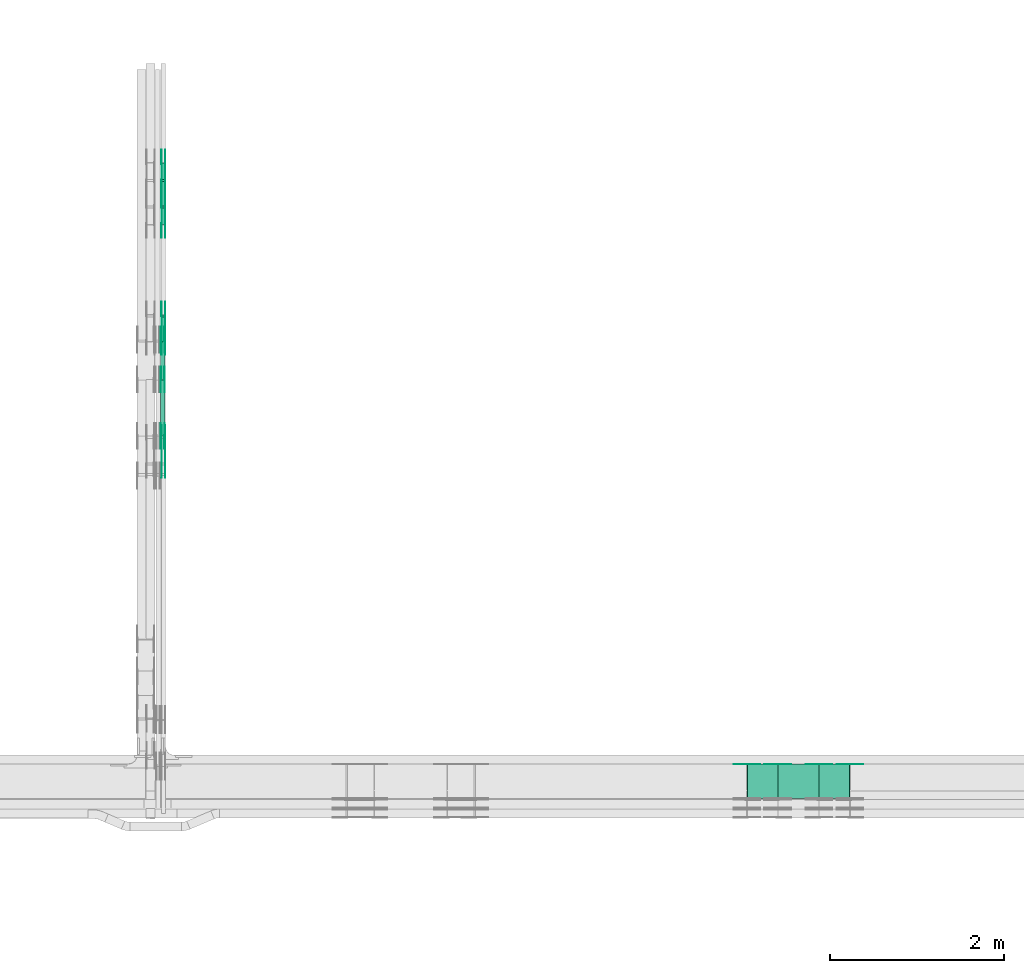
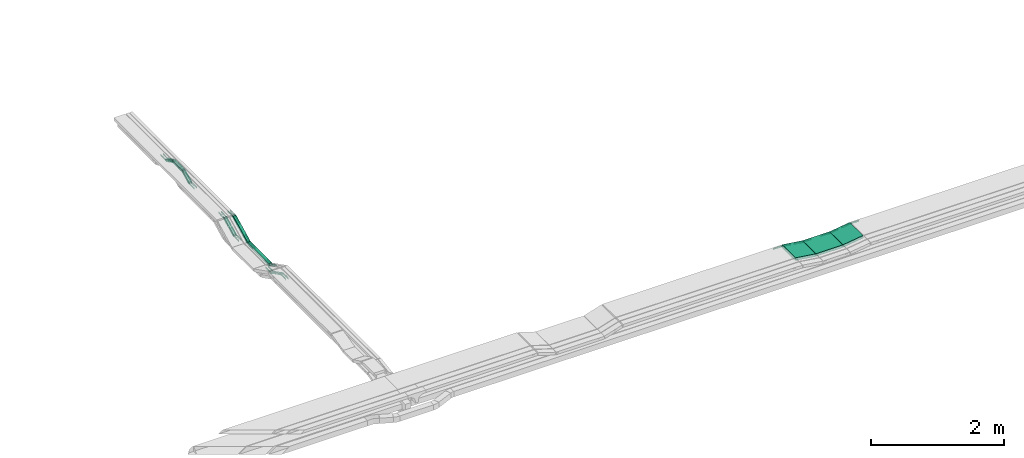
# One storey, part 20 of 27: 52 flow fittings, 9 flow segments.
"""IFC2X3 building model written with IfcOpenShell, lengths in millimetres."""

from ifc_helpers import new_model, entity, si_unit, converted_unit, derived_unit, direction, frame, frame_2d, origin, origin_2d_with_axis, place, context, subcontext, project, spatial, polyline, circle_curve, parameter, trimmed, segment, composite_curve, rectangle, outline, extrude, source, transform, mapped, material, type_object, type_shapes, element, save


model = new_model("IFC2X3")

# Units and contexts
model_context = context("Model", 3, precision=0.01, world=origin(), true_north=direction((6.12303176911189e-17, 1.0)))
body_context = subcontext(model_context, "Body", "Model", "MODEL_VIEW")
ifc_project = project(units=[si_unit("LENGTHUNIT", "METRE", prefix="MILLI"), si_unit("AREAUNIT", "SQUARE_METRE"), si_unit("VOLUMEUNIT", "CUBIC_METRE"), converted_unit("PLANEANGLEUNIT", "DEGREE", entity("IfcRatioMeasure", 0.0174532925199433), si_unit("PLANEANGLEUNIT", "RADIAN"), dimensions=[0, 0, 0, 0, 0, 0, 0]), si_unit("MASSUNIT", "GRAM", prefix="KILO"), derived_unit("MASSDENSITYUNIT", [(si_unit("MASSUNIT", "GRAM", prefix="KILO"), 1), (si_unit("LENGTHUNIT", "METRE"), -3)]), derived_unit("MOMENTOFINERTIAUNIT", [(si_unit("LENGTHUNIT", "METRE"), 4)]), si_unit("TIMEUNIT", "SECOND"), si_unit("FREQUENCYUNIT", "HERTZ"), si_unit("THERMODYNAMICTEMPERATUREUNIT", "DEGREE_CELSIUS"), derived_unit("THERMALTRANSMITTANCEUNIT", [(si_unit("MASSUNIT", "GRAM", prefix="KILO"), 1), (si_unit("THERMODYNAMICTEMPERATUREUNIT", "KELVIN"), -1), (si_unit("TIMEUNIT", "SECOND"), -3)]), derived_unit("VOLUMETRICFLOWRATEUNIT", [(si_unit("LENGTHUNIT", "METRE"), 3), (si_unit("TIMEUNIT", "SECOND"), -1)]), derived_unit("MASSFLOWRATEUNIT", [(si_unit("MASSUNIT", "GRAM", prefix="KILO"), 1), (si_unit("TIMEUNIT", "SECOND"), -1)]), derived_unit("ROTATIONALFREQUENCYUNIT", [(si_unit("TIMEUNIT", "SECOND"), -1)]), si_unit("ELECTRICCURRENTUNIT", "AMPERE"), si_unit("ELECTRICVOLTAGEUNIT", "VOLT"), si_unit("POWERUNIT", "WATT"), si_unit("FORCEUNIT", "NEWTON", prefix="KILO"), si_unit("ILLUMINANCEUNIT", "LUX"), si_unit("LUMINOUSFLUXUNIT", "LUMEN"), si_unit("LUMINOUSINTENSITYUNIT", "CANDELA"), derived_unit("USERDEFINED", [(si_unit("MASSUNIT", "GRAM", prefix="KILO"), -1), (si_unit("LENGTHUNIT", "METRE"), -2), (si_unit("TIMEUNIT", "SECOND"), 3), (si_unit("LUMINOUSFLUXUNIT", "LUMEN"), 1)]), derived_unit("LINEARVELOCITYUNIT", [(si_unit("LENGTHUNIT", "METRE"), 1), (si_unit("TIMEUNIT", "SECOND"), -1)]), si_unit("PRESSUREUNIT", "PASCAL"), derived_unit("USERDEFINED", [(si_unit("LENGTHUNIT", "METRE"), -2), (si_unit("MASSUNIT", "GRAM", prefix="KILO"), 1), (si_unit("TIMEUNIT", "SECOND"), -2)]), derived_unit("LINEARFORCEUNIT", [(si_unit("MASSUNIT", "GRAM", prefix="KILO"), 1), (si_unit("LENGTHUNIT", "METRE"), 1), (si_unit("TIMEUNIT", "SECOND"), -2), (si_unit("LENGTHUNIT", "METRE"), -1)]), derived_unit("PLANARFORCEUNIT", [(si_unit("MASSUNIT", "GRAM", prefix="KILO"), 1), (si_unit("LENGTHUNIT", "METRE"), 1), (si_unit("TIMEUNIT", "SECOND"), -2), (si_unit("LENGTHUNIT", "METRE"), -2)])], contexts=[model_context])

# Site, building, storey
site_placement = place(None, origin())
site = spatial("IfcSite", under=ifc_project, at=site_placement, CompositionType="ELEMENT")
building_placement = place(site_placement, origin())
building = spatial("IfcBuilding", under=site, at=building_placement, CompositionType="ELEMENT")
storey_placement = place(building_placement, origin())
storey = spatial("IfcBuildingStorey", under=building, at=storey_placement, CompositionType="ELEMENT", Elevation=0.0)

# Flow segments
cable_carrier_segment_type = type_object("IfcCableCarrierSegmentType", PredefinedType="CABLETRAYSEGMENT")
flow_segment_1_placement = place(storey_placement, frame((47019.82, 13767.29, 2456.23)))
element("IfcFlowSegment", 1, at=flow_segment_1_placement, inside=storey, type_object=cable_carrier_segment_type, context=body_context, shape_type="SweptSolid", body=[
    extrude(rectangle(XDim=50.000000000001, YDim=317.472558761843, at=frame_2d((0.0, 0.0), x_axis=(0.0, 1.0))), frame((0.0, 153.0, 93.77), z_axis=(1.0, 0.0, 0.0), x_axis=(0.0, -0.892980854206745, -0.450094650068397)), (0.0, 0.0, 1.0), 50.0000000000059),
])
flow_segment_2_placement = place(storey_placement, frame((47012.18, 12686.39, 2574.95)))
element("IfcFlowSegment", 2, at=flow_segment_2_placement, inside=storey, type_object=cable_carrier_segment_type, context=body_context, shape_type="SweptSolid", body=[
    extrude(rectangle(XDim=642.104660925129, YDim=50.000000000006, at=origin_2d_with_axis()), frame((25.0, 321.05, 0.0), z_axis=(0.0, 0.0, 1.0), x_axis=(0.0, 1.0, 0.0)), (0.0, 0.0, 1.0), 50.0000000000005),
])
flow_segment_3_placement = place(storey_placement, frame((47012.18, 13332.18, 2581.18)))
element("IfcFlowSegment", 3, at=flow_segment_3_placement, inside=storey, type_object=cable_carrier_segment_type, context=body_context, shape_type="SweptSolid", body=[
    extrude(rectangle(XDim=50.000000000001, YDim=484.209321850271, at=frame_2d((0.0, 0.0), x_axis=(0.0, 1.0))), frame((0.0, 227.45, 131.29), z_axis=(1.0, 0.0, 0.0), x_axis=(0.0, -0.892980854206697, -0.450094650068491)), (0.0, 0.0, 1.0), 50.000000000006),
])
flow_segment_4_placement = place(storey_placement, frame((54101.13, 8520.0, 2800.0)))
element("IfcFlowSegment", 4, at=flow_segment_4_placement, inside=storey, type_object=cable_carrier_segment_type, context=body_context, shape_type="SweptSolid", body=[
    extrude(rectangle(XDim=466.843004853572, YDim=400.0, at=origin_2d_with_axis()), frame((233.42, 200.0, 0.0), z_axis=(0.0, 0.0, 1.0), x_axis=(-1.0, 0.0, 0.0)), (0.0, 0.0, 1.0), 49.9999999999995),
])
flow_segment_5_placement = place(storey_placement, frame((47019.82, 15325.71, 2700.0)))
element("IfcFlowSegment", 5, at=flow_segment_5_placement, inside=storey, type_object=cable_carrier_segment_type, context=body_context, shape_type="SweptSolid", body=[
    extrude(rectangle(XDim=276.67146144988, YDim=50.000000000006, at=origin_2d_with_axis()), frame((25.0, 138.34, 0.0), z_axis=(0.0, 0.0, 1.0), x_axis=(0.0, 1.0, 0.0)), (0.0, 0.0, 1.0), 49.9999999999995),
])
flow_segment_6_placement = place(storey_placement, frame((47019.82, 15108.94, 2605.9)))
element("IfcFlowSegment", 6, at=flow_segment_6_placement, inside=storey, type_object=cable_carrier_segment_type, context=body_context, shape_type="SweptSolid", body=[
    extrude(rectangle(XDim=49.9999999999993, YDim=212.726848186774, at=frame_2d((0.0, 0.0), x_axis=(0.0, 1.0))), frame((0.0, 106.56, 69.1), z_axis=(1.0, 0.0, 0.0), x_axis=(0.0, -0.898794046299049, -0.438371146789319)), (0.0, 0.0, 1.0), 50.000000000006),
])
flow_segment_7_placement = place(storey_placement, frame((47019.82, 15606.03, 2605.9)))
element("IfcFlowSegment", 7, at=flow_segment_7_placement, inside=storey, type_object=cable_carrier_segment_type, context=body_context, shape_type="SweptSolid", body=[
    extrude(rectangle(XDim=49.9999999999992, YDim=212.726848186706, at=frame_2d((0.0, 0.0), x_axis=(0.0, 1.0))), frame((0.0, 106.56, 69.1), z_axis=(1.0, 0.0, 0.0), x_axis=(0.0, 0.898794046298994, -0.438371146789433)), (0.0, 0.0, 1.0), 50.0000000000059),
])
flow_segment_8_placement = place(storey_placement, frame((54570.52, 8520.0, 2800.66)))
element("IfcFlowSegment", 8, at=flow_segment_8_placement, inside=storey, type_object=cable_carrier_segment_type, context=body_context, shape_type="SweptSolid", body=[
    extrude(rectangle(XDim=50.0000000000001, YDim=353.209071623864, at=frame_2d((0.0, 0.0), x_axis=(0.0, 1.0))), frame((178.37, 0.0, 49.34), z_axis=(0.0, 1.0, 0.0), x_axis=(-0.990268068741569, 0.0, -0.139173100960075)), (0.0, 0.0, 1.0), 400.0),
])
flow_segment_9_placement = place(storey_placement, frame((53741.85, 8520.0, 2800.66)))
element("IfcFlowSegment", 9, at=flow_segment_9_placement, inside=storey, type_object=cable_carrier_segment_type, context=body_context, shape_type="SweptSolid", body=[
    extrude(rectangle(XDim=49.9999999999989, YDim=353.209071624417, at=frame_2d((0.0, 0.0), x_axis=(0.0, 1.0))), frame((178.37, 0.0, 49.34), z_axis=(0.0, 1.0, 0.0), x_axis=(0.990268068741587, 0.0, -0.139173100959945)), (0.0, 0.0, 1.0), 399.999999999999),
])

# Flow fittings
ifc_material = material(Name="G")
cable_carrier_fitting_type_1 = type_object("IfcCableCarrierFittingType", PredefinedType="NOTDEFINED", material=ifc_material)
shared_shape_1 = source(origin(), body_context, "Body", "SweptSolid", [
    extrude(outline(composite_curve([segment(trimmed(circle_curve(frame_2d((-44.59, 0.0), x_axis=(1.0, 0.0)), 12.5), [parameter(90.0000000000007)], [parameter(270.0)], True, "PARAMETER"), True, "CONTINUOUS"), segment(polyline([(-44.59, -12.5), (-33.09, -12.5)]), True, "CONTINUOUS"), segment(polyline([(-33.09, -12.5), (-31.23, -14.5)]), True, "CONTINUOUS"), segment(polyline([(-31.23, -14.5), (108.91, -14.5)]), True, "CONTINUOUS"), segment(polyline([(108.91, -14.5), (108.91, 14.5)]), True, "CONTINUOUS"), segment(polyline([(108.91, 14.5), (-31.23, 14.5)]), True, "CONTINUOUS"), segment(polyline([(-31.23, 14.5), (-33.09, 12.5)]), True, "CONTINUOUS"), segment(polyline([(-33.09, 12.5), (-44.59, 12.5)]), True, "CONTINUOUS")], self_intersect=False)), frame((44.59, 0.0, 0.0), z_axis=(0.0, 0.0, -1.0), x_axis=(1.0, 0.0, 0.0)), (0.0, 0.0, -1.0), 2.0),
])
type_shapes(cable_carrier_fitting_type_1, [shared_shape_1])
flow_fitting_1_placement = place(storey_placement, frame((47024.36, 13771.5, 2475.0), z_axis=(-1.0, 0.0, 0.0), x_axis=(0.0, -1.0, 0.0)))
element("IfcFlowFitting", 10, at=flow_fitting_1_placement, inside=storey, type_object=cable_carrier_fitting_type_1, material=ifc_material, context=body_context, shape_type="MappedRepresentation", body=[
    mapped(shared_shape_1, transform((0.0, 0.0, 0.0), scale=1.0)),
])
cable_carrier_fitting_type_2 = type_object("IfcCableCarrierFittingType", PredefinedType="NOTDEFINED", material=ifc_material)
type_shapes(cable_carrier_fitting_type_2, [shared_shape_1])
flow_fitting_2_placement = place(storey_placement, frame((47063.28, 13771.5, 2475.0), z_axis=(1.0, 0.0, 0.0), x_axis=(0.0, 0.892980854206722, 0.450094650068442)))
element("IfcFlowFitting", 11, at=flow_fitting_2_placement, inside=storey, type_object=cable_carrier_fitting_type_2, material=ifc_material, context=body_context, shape_type="MappedRepresentation", body=[
    mapped(shared_shape_1, transform((0.0, 0.0, 0.0), scale=1.0)),
])
flow_fitting_3_placement = place(storey_placement, frame((47065.28, 12652.1, 2475.0), z_axis=(1.0, 0.0, 0.0), x_axis=(0.0, 1.0, 0.0)))
element("IfcFlowFitting", 12, at=flow_fitting_3_placement, inside=storey, type_object=cable_carrier_fitting_type_1, material=ifc_material, context=body_context, shape_type="MappedRepresentation", body=[
    mapped(shared_shape_1, transform((0.0, 0.0, 0.0), scale=1.0)),
])
flow_fitting_4_placement = place(storey_placement, frame((47026.36, 12652.1, 2475.0), z_axis=(-1.0, 0.0, 0.0), x_axis=(0.0, -0.892980854206722, 0.450094650068442)))
element("IfcFlowFitting", 13, at=flow_fitting_4_placement, inside=storey, type_object=cable_carrier_fitting_type_2, material=ifc_material, context=body_context, shape_type="MappedRepresentation", body=[
    mapped(shared_shape_1, transform((0.0, 0.0, 0.0), scale=1.0)),
])
flow_fitting_5_placement = place(storey_placement, frame((47065.28, 12354.51, 2625.0), z_axis=(1.0, 0.0, 0.0), x_axis=(0.0, -1.0, 0.0)))
element("IfcFlowFitting", 14, at=flow_fitting_5_placement, inside=storey, type_object=cable_carrier_fitting_type_1, material=ifc_material, context=body_context, shape_type="MappedRepresentation", body=[
    mapped(shared_shape_1, transform((0.0, 0.0, 0.0), scale=1.0)),
])
flow_fitting_6_placement = place(storey_placement, frame((47026.36, 12354.51, 2625.0), z_axis=(-1.0, 0.0, 0.0), x_axis=(0.0, 0.892980854206722, -0.450094650068442)))
element("IfcFlowFitting", 15, at=flow_fitting_6_placement, inside=storey, type_object=cable_carrier_fitting_type_2, material=ifc_material, context=body_context, shape_type="MappedRepresentation", body=[
    mapped(shared_shape_1, transform((0.0, 0.0, 0.0), scale=1.0)),
])
flow_fitting_7_placement = place(storey_placement, frame((47057.64, 12678.49, 2599.95), z_axis=(1.0, 0.0, 0.0), x_axis=(0.0, 1.0, 0.0)))
element("IfcFlowFitting", 16, at=flow_fitting_7_placement, inside=storey, type_object=cable_carrier_fitting_type_1, material=ifc_material, context=body_context, shape_type="MappedRepresentation", body=[
    mapped(shared_shape_1, transform((0.0, 0.0, 0.0), scale=1.0)),
])
flow_fitting_8_placement = place(storey_placement, frame((47018.72, 12678.49, 2599.95), z_axis=(-1.0, 0.0, 0.0), x_axis=(0.0, -0.892980854206714, 0.450094650068457)))
element("IfcFlowFitting", 17, at=flow_fitting_8_placement, inside=storey, type_object=cable_carrier_fitting_type_2, material=ifc_material, context=body_context, shape_type="MappedRepresentation", body=[
    mapped(shared_shape_1, transform((0.0, 0.0, 0.0), scale=1.0)),
])
cable_carrier_fitting_type_3 = type_object("IfcCableCarrierFittingType", PredefinedType="NOTDEFINED", material=ifc_material)
type_shapes(cable_carrier_fitting_type_3, [shared_shape_1])
flow_fitting_9_placement = place(storey_placement, frame((47016.72, 13336.39, 2599.95), z_axis=(-1.0, 0.0, 0.0), x_axis=(0.0, -1.0, 0.0)))
element("IfcFlowFitting", 18, at=flow_fitting_9_placement, inside=storey, type_object=cable_carrier_fitting_type_3, material=ifc_material, context=body_context, shape_type="MappedRepresentation", body=[
    mapped(shared_shape_1, transform((0.0, 0.0, 0.0), scale=1.0)),
])
flow_fitting_10_placement = place(storey_placement, frame((47055.64, 13336.39, 2599.95), z_axis=(1.0, 0.0, 0.0), x_axis=(0.0, 0.892980854206714, 0.450094650068457)))
element("IfcFlowFitting", 19, at=flow_fitting_10_placement, inside=storey, type_object=cable_carrier_fitting_type_2, material=ifc_material, context=body_context, shape_type="MappedRepresentation", body=[
    mapped(shared_shape_1, transform((0.0, 0.0, 0.0), scale=1.0)),
])
flow_fitting_11_placement = place(storey_placement, frame((47057.64, 13782.88, 2825.0), z_axis=(1.0, 0.0, 0.0), x_axis=(0.0, -0.892980854206745, -0.450094650068397)))
element("IfcFlowFitting", 20, at=flow_fitting_11_placement, inside=storey, type_object=cable_carrier_fitting_type_1, material=ifc_material, context=body_context, shape_type="MappedRepresentation", body=[
    mapped(shared_shape_1, transform((0.0, 0.0, 0.0), scale=1.0)),
])
flow_fitting_12_placement = place(storey_placement, frame((47018.72, 13782.88, 2825.0), z_axis=(-1.0, 0.0, 0.0), x_axis=(0.0, 1.0, 0.0)))
element("IfcFlowFitting", 21, at=flow_fitting_12_placement, inside=storey, type_object=cable_carrier_fitting_type_2, material=ifc_material, context=body_context, shape_type="MappedRepresentation", body=[
    mapped(shared_shape_1, transform((0.0, 0.0, 0.0), scale=1.0)),
])
flow_fitting_13_placement = place(storey_placement, frame((47024.36, 15318.01, 2725.0), z_axis=(-1.0, 0.0, 0.0), x_axis=(0.0, 1.0, 0.0)))
element("IfcFlowFitting", 22, at=flow_fitting_13_placement, inside=storey, type_object=cable_carrier_fitting_type_1, material=ifc_material, context=body_context, shape_type="MappedRepresentation", body=[
    mapped(shared_shape_1, transform((0.0, 0.0, 0.0), scale=1.0)),
])
flow_fitting_14_placement = place(storey_placement, frame((47063.28, 15318.01, 2725.0), z_axis=(1.0, 0.0, 0.0), x_axis=(0.0, -0.898794046298952, -0.438371146789519)))
element("IfcFlowFitting", 23, at=flow_fitting_14_placement, inside=storey, type_object=cable_carrier_fitting_type_2, material=ifc_material, context=body_context, shape_type="MappedRepresentation", body=[
    mapped(shared_shape_1, transform((0.0, 0.0, 0.0), scale=1.0)),
])
flow_fitting_15_placement = place(storey_placement, frame((47065.28, 15610.07, 2725.0), z_axis=(1.0, 0.0, 0.0), x_axis=(0.0, -1.0, 0.0)))
element("IfcFlowFitting", 24, at=flow_fitting_15_placement, inside=storey, type_object=cable_carrier_fitting_type_1, material=ifc_material, context=body_context, shape_type="MappedRepresentation", body=[
    mapped(shared_shape_1, transform((0.0, 0.0, 0.0), scale=1.0)),
])
flow_fitting_16_placement = place(storey_placement, frame((47026.36, 15610.07, 2725.0), z_axis=(-1.0, 0.0, 0.0), x_axis=(0.0, 0.898794046298952, -0.438371146789519)))
element("IfcFlowFitting", 25, at=flow_fitting_16_placement, inside=storey, type_object=cable_carrier_fitting_type_2, material=ifc_material, context=body_context, shape_type="MappedRepresentation", body=[
    mapped(shared_shape_1, transform((0.0, 0.0, 0.0), scale=1.0)),
])
flow_fitting_17_placement = place(storey_placement, frame((47065.28, 15815.1, 2625.0), z_axis=(1.0, 0.0, 0.0), x_axis=(0.0, 1.0, 0.0)))
element("IfcFlowFitting", 26, at=flow_fitting_17_placement, inside=storey, type_object=cable_carrier_fitting_type_1, material=ifc_material, context=body_context, shape_type="MappedRepresentation", body=[
    mapped(shared_shape_1, transform((0.0, 0.0, 0.0), scale=1.0)),
])
flow_fitting_18_placement = place(storey_placement, frame((47026.36, 15815.1, 2625.0), z_axis=(-1.0, 0.0, 0.0), x_axis=(0.0, -0.898794046299012, 0.438371146789395)))
element("IfcFlowFitting", 27, at=flow_fitting_18_placement, inside=storey, type_object=cable_carrier_fitting_type_2, material=ifc_material, context=body_context, shape_type="MappedRepresentation", body=[
    mapped(shared_shape_1, transform((0.0, 0.0, 0.0), scale=1.0)),
])
flow_fitting_19_placement = place(storey_placement, frame((47024.36, 14069.09, 2625.0), z_axis=(-1.0, 0.0, 0.0), x_axis=(0.0, 1.0, 0.0)))
element("IfcFlowFitting", 28, at=flow_fitting_19_placement, inside=storey, type_object=cable_carrier_fitting_type_1, material=ifc_material, context=body_context, shape_type="MappedRepresentation", body=[
    mapped(shared_shape_1, transform((0.0, 0.0, 0.0), scale=1.0)),
])
flow_fitting_20_placement = place(storey_placement, frame((47063.28, 14069.09, 2625.0), z_axis=(1.0, 0.0, 0.0), x_axis=(0.0, -0.892980854206747, -0.450094650068392)))
element("IfcFlowFitting", 29, at=flow_fitting_20_placement, inside=storey, type_object=cable_carrier_fitting_type_2, material=ifc_material, context=body_context, shape_type="MappedRepresentation", body=[
    mapped(shared_shape_1, transform((0.0, 0.0, 0.0), scale=1.0)),
])
flow_fitting_21_placement = place(storey_placement, frame((47024.36, 15112.98, 2625.0), z_axis=(-1.0, 0.0, 0.0), x_axis=(0.0, -1.0, 0.0)))
element("IfcFlowFitting", 30, at=flow_fitting_21_placement, inside=storey, type_object=cable_carrier_fitting_type_1, material=ifc_material, context=body_context, shape_type="MappedRepresentation", body=[
    mapped(shared_shape_1, transform((0.0, 0.0, 0.0), scale=1.0)),
])
flow_fitting_22_placement = place(storey_placement, frame((47063.28, 15112.98, 2625.0), z_axis=(1.0, 0.0, 0.0), x_axis=(0.0, 0.898794046299068, 0.43837114678928)))
element("IfcFlowFitting", 31, at=flow_fitting_22_placement, inside=storey, type_object=cable_carrier_fitting_type_2, material=ifc_material, context=body_context, shape_type="MappedRepresentation", body=[
    mapped(shared_shape_1, transform((0.0, 0.0, 0.0), scale=1.0)),
])
flow_fitting_23_placement = place(storey_placement, frame((54571.0, 8915.46, 2825.0), z_axis=(0.0, 1.0, 0.0), x_axis=(-1.0, 0.0, 0.0)))
element("IfcFlowFitting", 32, at=flow_fitting_23_placement, inside=storey, type_object=cable_carrier_fitting_type_1, material=ifc_material, context=body_context, shape_type="MappedRepresentation", body=[
    mapped(shared_shape_1, transform((0.0, 0.0, 0.0), scale=1.0)),
])
for number, where, z_axis, x_axis in (
    (33, (54098.1, 8913.46, 2825.0), (0.0, 1.0, 0.0), (-0.990268068741579, 0.0, 0.139173100960007)),
    (34, (53742.33, 8913.46, 2875.0), (0.0, 1.0, 0.0), (0.990268068741587, 0.0, -0.139173100959947)),
):
    element("IfcFlowFitting", number, at=place(storey_placement, frame(where, z_axis=z_axis, x_axis=x_axis)), inside=storey, type_object=cable_carrier_fitting_type_2, material=ifc_material, context=body_context, shape_type="MappedRepresentation", body=[
        mapped(shared_shape_1, transform((0.0, 0.0, 0.0), scale=1.0)),
    ])
flow_fitting_24_placement = place(storey_placement, frame((54926.77, 8915.46, 2875.0), z_axis=(0.0, 1.0, 0.0), x_axis=(1.0, 0.0, 0.0)))
element("IfcFlowFitting", 35, at=flow_fitting_24_placement, inside=storey, type_object=cable_carrier_fitting_type_1, material=ifc_material, context=body_context, shape_type="MappedRepresentation", body=[
    mapped(shared_shape_1, transform((0.0, 0.0, 0.0), scale=1.0)),
])
cable_carrier_fitting_type_4 = type_object("IfcCableCarrierFittingType", PredefinedType="NOTDEFINED", material=ifc_material)
shared_shape_2 = source(origin(), body_context, "Body", "SweptSolid", [
    extrude(outline(composite_curve([segment(trimmed(circle_curve(frame_2d((-44.59, 0.0), x_axis=(1.0, 0.0)), 12.5), [parameter(90.0000000000007)], [parameter(270.0)], True, "PARAMETER"), True, "CONTINUOUS"), segment(polyline([(-44.59, -12.5), (-33.09, -12.5)]), True, "CONTINUOUS"), segment(polyline([(-33.09, -12.5), (-31.23, -14.5)]), True, "CONTINUOUS"), segment(polyline([(-31.23, -14.5), (108.91, -14.5)]), True, "CONTINUOUS"), segment(polyline([(108.91, -14.5), (108.91, 14.5)]), True, "CONTINUOUS"), segment(polyline([(108.91, 14.5), (-31.23, 14.5)]), True, "CONTINUOUS"), segment(polyline([(-31.23, 14.5), (-33.09, 12.5)]), True, "CONTINUOUS"), segment(polyline([(-33.09, 12.5), (-44.59, 12.5)]), True, "CONTINUOUS")], self_intersect=False)), frame((44.59, 0.0, 0.0)), (0.0, 0.0, 1.0), 2.0),
])
type_shapes(cable_carrier_fitting_type_4, [shared_shape_2])
flow_fitting_25_placement = place(storey_placement, frame((47065.28, 13771.5, 2475.0), z_axis=(1.0, 0.0, 0.0), x_axis=(0.0, -1.0, 0.0)))
element("IfcFlowFitting", 36, at=flow_fitting_25_placement, inside=storey, type_object=cable_carrier_fitting_type_4, material=ifc_material, context=body_context, shape_type="MappedRepresentation", body=[
    mapped(shared_shape_2, transform((0.0, 0.0, 0.0), scale=1.0)),
])
cable_carrier_fitting_type_5 = type_object("IfcCableCarrierFittingType", PredefinedType="NOTDEFINED", material=ifc_material)
type_shapes(cable_carrier_fitting_type_5, [shared_shape_2])
flow_fitting_26_placement = place(storey_placement, frame((47026.36, 13771.5, 2475.0), z_axis=(-1.0, 0.0, 0.0), x_axis=(0.0, 0.892980854206722, 0.450094650068442)))
element("IfcFlowFitting", 37, at=flow_fitting_26_placement, inside=storey, type_object=cable_carrier_fitting_type_5, material=ifc_material, context=body_context, shape_type="MappedRepresentation", body=[
    mapped(shared_shape_2, transform((0.0, 0.0, 0.0), scale=1.0)),
])
flow_fitting_27_placement = place(storey_placement, frame((47024.36, 12652.1, 2475.0), z_axis=(-1.0, 0.0, 0.0), x_axis=(0.0, 1.0, 0.0)))
element("IfcFlowFitting", 38, at=flow_fitting_27_placement, inside=storey, type_object=cable_carrier_fitting_type_4, material=ifc_material, context=body_context, shape_type="MappedRepresentation", body=[
    mapped(shared_shape_2, transform((0.0, 0.0, 0.0), scale=1.0)),
])
flow_fitting_28_placement = place(storey_placement, frame((47063.28, 12652.1, 2475.0), z_axis=(1.0, 0.0, 0.0), x_axis=(0.0, -0.892980854206722, 0.450094650068442)))
element("IfcFlowFitting", 39, at=flow_fitting_28_placement, inside=storey, type_object=cable_carrier_fitting_type_5, material=ifc_material, context=body_context, shape_type="MappedRepresentation", body=[
    mapped(shared_shape_2, transform((0.0, 0.0, 0.0), scale=1.0)),
])
flow_fitting_29_placement = place(storey_placement, frame((47024.36, 12354.51, 2625.0), z_axis=(-1.0, 0.0, 0.0), x_axis=(0.0, -1.0, 0.0)))
element("IfcFlowFitting", 40, at=flow_fitting_29_placement, inside=storey, type_object=cable_carrier_fitting_type_4, material=ifc_material, context=body_context, shape_type="MappedRepresentation", body=[
    mapped(shared_shape_2, transform((0.0, 0.0, 0.0), scale=1.0)),
])
flow_fitting_30_placement = place(storey_placement, frame((47063.28, 12354.51, 2625.0), z_axis=(1.0, 0.0, 0.0), x_axis=(0.0, 0.892980854206722, -0.450094650068442)))
element("IfcFlowFitting", 41, at=flow_fitting_30_placement, inside=storey, type_object=cable_carrier_fitting_type_5, material=ifc_material, context=body_context, shape_type="MappedRepresentation", body=[
    mapped(shared_shape_2, transform((0.0, 0.0, 0.0), scale=1.0)),
])
flow_fitting_31_placement = place(storey_placement, frame((47016.72, 12678.49, 2599.95), z_axis=(-1.0, 0.0, 0.0), x_axis=(0.0, 1.0, 0.0)))
element("IfcFlowFitting", 42, at=flow_fitting_31_placement, inside=storey, type_object=cable_carrier_fitting_type_4, material=ifc_material, context=body_context, shape_type="MappedRepresentation", body=[
    mapped(shared_shape_2, transform((0.0, 0.0, 0.0), scale=1.0)),
])
flow_fitting_32_placement = place(storey_placement, frame((47055.64, 12678.49, 2599.95), z_axis=(1.0, 0.0, 0.0), x_axis=(0.0, -0.892980854206714, 0.450094650068457)))
element("IfcFlowFitting", 43, at=flow_fitting_32_placement, inside=storey, type_object=cable_carrier_fitting_type_5, material=ifc_material, context=body_context, shape_type="MappedRepresentation", body=[
    mapped(shared_shape_2, transform((0.0, 0.0, 0.0), scale=1.0)),
])
cable_carrier_fitting_type_6 = type_object("IfcCableCarrierFittingType", PredefinedType="NOTDEFINED", material=ifc_material)
type_shapes(cable_carrier_fitting_type_6, [shared_shape_2])
flow_fitting_33_placement = place(storey_placement, frame((47057.64, 13336.39, 2599.95), z_axis=(1.0, 0.0, 0.0), x_axis=(0.0, -1.0, 0.0)))
element("IfcFlowFitting", 44, at=flow_fitting_33_placement, inside=storey, type_object=cable_carrier_fitting_type_6, material=ifc_material, context=body_context, shape_type="MappedRepresentation", body=[
    mapped(shared_shape_2, transform((0.0, 0.0, 0.0), scale=1.0)),
])
flow_fitting_34_placement = place(storey_placement, frame((47018.72, 13336.39, 2599.95), z_axis=(-1.0, 0.0, 0.0), x_axis=(0.0, 0.892980854206714, 0.450094650068457)))
element("IfcFlowFitting", 45, at=flow_fitting_34_placement, inside=storey, type_object=cable_carrier_fitting_type_5, material=ifc_material, context=body_context, shape_type="MappedRepresentation", body=[
    mapped(shared_shape_2, transform((0.0, 0.0, 0.0), scale=1.0)),
])
flow_fitting_35_placement = place(storey_placement, frame((47016.72, 13782.88, 2825.0), z_axis=(-1.0, 0.0, 0.0), x_axis=(0.0, -0.892980854206745, -0.450094650068397)))
element("IfcFlowFitting", 46, at=flow_fitting_35_placement, inside=storey, type_object=cable_carrier_fitting_type_4, material=ifc_material, context=body_context, shape_type="MappedRepresentation", body=[
    mapped(shared_shape_2, transform((0.0, 0.0, 0.0), scale=1.0)),
])
flow_fitting_36_placement = place(storey_placement, frame((47055.64, 13782.88, 2825.0), z_axis=(1.0, 0.0, 0.0), x_axis=(0.0, 1.0, 0.0)))
element("IfcFlowFitting", 47, at=flow_fitting_36_placement, inside=storey, type_object=cable_carrier_fitting_type_5, material=ifc_material, context=body_context, shape_type="MappedRepresentation", body=[
    mapped(shared_shape_2, transform((0.0, 0.0, 0.0), scale=1.0)),
])
flow_fitting_37_placement = place(storey_placement, frame((47065.28, 15318.01, 2725.0), z_axis=(1.0, 0.0, 0.0), x_axis=(0.0, 1.0, 0.0)))
element("IfcFlowFitting", 48, at=flow_fitting_37_placement, inside=storey, type_object=cable_carrier_fitting_type_4, material=ifc_material, context=body_context, shape_type="MappedRepresentation", body=[
    mapped(shared_shape_2, transform((0.0, 0.0, 0.0), scale=1.0)),
])
flow_fitting_38_placement = place(storey_placement, frame((47026.36, 15318.01, 2725.0), z_axis=(-1.0, 0.0, 0.0), x_axis=(0.0, -0.898794046298952, -0.438371146789519)))
element("IfcFlowFitting", 49, at=flow_fitting_38_placement, inside=storey, type_object=cable_carrier_fitting_type_5, material=ifc_material, context=body_context, shape_type="MappedRepresentation", body=[
    mapped(shared_shape_2, transform((0.0, 0.0, 0.0), scale=1.0)),
])
flow_fitting_39_placement = place(storey_placement, frame((47024.36, 15610.07, 2725.0), z_axis=(-1.0, 0.0, 0.0), x_axis=(0.0, -1.0, 0.0)))
element("IfcFlowFitting", 50, at=flow_fitting_39_placement, inside=storey, type_object=cable_carrier_fitting_type_4, material=ifc_material, context=body_context, shape_type="MappedRepresentation", body=[
    mapped(shared_shape_2, transform((0.0, 0.0, 0.0), scale=1.0)),
])
flow_fitting_40_placement = place(storey_placement, frame((47063.28, 15610.07, 2725.0), z_axis=(1.0, 0.0, 0.0), x_axis=(0.0, 0.898794046298952, -0.438371146789519)))
element("IfcFlowFitting", 51, at=flow_fitting_40_placement, inside=storey, type_object=cable_carrier_fitting_type_5, material=ifc_material, context=body_context, shape_type="MappedRepresentation", body=[
    mapped(shared_shape_2, transform((0.0, 0.0, 0.0), scale=1.0)),
])
flow_fitting_41_placement = place(storey_placement, frame((47024.36, 15815.1, 2625.0), z_axis=(-1.0, 0.0, 0.0), x_axis=(0.0, 1.0, 0.0)))
element("IfcFlowFitting", 52, at=flow_fitting_41_placement, inside=storey, type_object=cable_carrier_fitting_type_4, material=ifc_material, context=body_context, shape_type="MappedRepresentation", body=[
    mapped(shared_shape_2, transform((0.0, 0.0, 0.0), scale=1.0)),
])
flow_fitting_42_placement = place(storey_placement, frame((47063.28, 15815.1, 2625.0), z_axis=(1.0, 0.0, 0.0), x_axis=(0.0, -0.898794046299012, 0.438371146789395)))
element("IfcFlowFitting", 53, at=flow_fitting_42_placement, inside=storey, type_object=cable_carrier_fitting_type_5, material=ifc_material, context=body_context, shape_type="MappedRepresentation", body=[
    mapped(shared_shape_2, transform((0.0, 0.0, 0.0), scale=1.0)),
])
flow_fitting_43_placement = place(storey_placement, frame((47065.28, 14069.09, 2625.0), z_axis=(1.0, 0.0, 0.0), x_axis=(0.0, 1.0, 0.0)))
element("IfcFlowFitting", 54, at=flow_fitting_43_placement, inside=storey, type_object=cable_carrier_fitting_type_4, material=ifc_material, context=body_context, shape_type="MappedRepresentation", body=[
    mapped(shared_shape_2, transform((0.0, 0.0, 0.0), scale=1.0)),
])
flow_fitting_44_placement = place(storey_placement, frame((47026.36, 14069.09, 2625.0), z_axis=(-1.0, 0.0, 0.0), x_axis=(0.0, -0.892980854206747, -0.450094650068392)))
element("IfcFlowFitting", 55, at=flow_fitting_44_placement, inside=storey, type_object=cable_carrier_fitting_type_5, material=ifc_material, context=body_context, shape_type="MappedRepresentation", body=[
    mapped(shared_shape_2, transform((0.0, 0.0, 0.0), scale=1.0)),
])
flow_fitting_45_placement = place(storey_placement, frame((47065.28, 15112.98, 2625.0), z_axis=(1.0, 0.0, 0.0), x_axis=(0.0, -1.0, 0.0)))
element("IfcFlowFitting", 56, at=flow_fitting_45_placement, inside=storey, type_object=cable_carrier_fitting_type_4, material=ifc_material, context=body_context, shape_type="MappedRepresentation", body=[
    mapped(shared_shape_2, transform((0.0, 0.0, 0.0), scale=1.0)),
])
for number, where, z_axis, x_axis in (
    (57, (47026.36, 15112.98, 2625.0), (-1.0, 0.0, 0.0), (0.0, 0.898794046299068, 0.43837114678928)),
    (58, (54571.0, 8913.46, 2825.0), (0.0, 1.0, 0.0), (0.99026806874157, 0.0, 0.139173100960071)),
):
    element("IfcFlowFitting", number, at=place(storey_placement, frame(where, z_axis=z_axis, x_axis=x_axis)), inside=storey, type_object=cable_carrier_fitting_type_5, material=ifc_material, context=body_context, shape_type="MappedRepresentation", body=[
        mapped(shared_shape_2, transform((0.0, 0.0, 0.0), scale=1.0)),
    ])
for number, where, z_axis, x_axis in (
    (59, (54098.1, 8915.46, 2825.0), (0.0, 1.0, 0.0), (1.0, 0.0, 0.0)),
    (60, (53742.33, 8915.46, 2875.0), (0.0, 1.0, 0.0), (-1.0, 0.0, 0.0)),
):
    element("IfcFlowFitting", number, at=place(storey_placement, frame(where, z_axis=z_axis, x_axis=x_axis)), inside=storey, type_object=cable_carrier_fitting_type_4, material=ifc_material, context=body_context, shape_type="MappedRepresentation", body=[
        mapped(shared_shape_2, transform((0.0, 0.0, 0.0), scale=1.0)),
    ])
flow_fitting_46_placement = place(storey_placement, frame((54926.77, 8913.46, 2875.0), z_axis=(0.0, 1.0, 0.0), x_axis=(-0.990268068741573, 0.0, -0.139173100960048)))
element("IfcFlowFitting", 61, at=flow_fitting_46_placement, inside=storey, type_object=cable_carrier_fitting_type_5, material=ifc_material, context=body_context, shape_type="MappedRepresentation", body=[
    mapped(shared_shape_2, transform((0.0, 0.0, 0.0), scale=1.0)),
])

save(model, "model.ifc")
